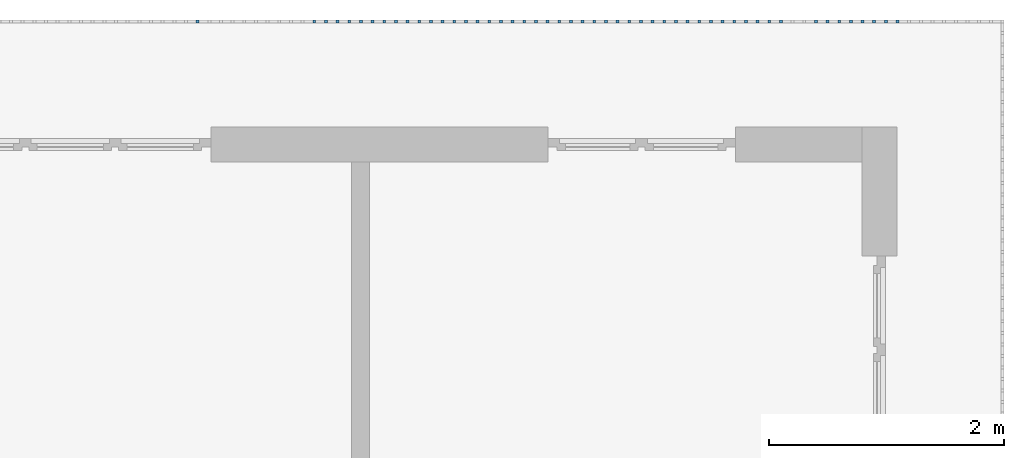
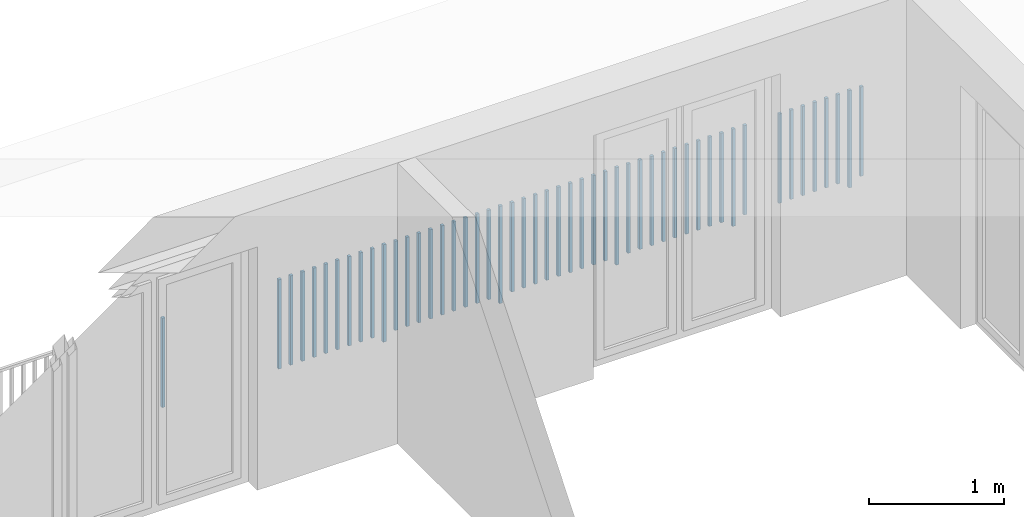
# One storey, part 53 of 54: 50 building element parts, 1 element without a shape of its own.
"""IFC4 building model written with IfcOpenShell, lengths in metres."""

from ifc_helpers import new_model, entity, si_unit, converted_unit, derived_unit, direction, frame, origin_with_axes, place, context, subcontext, project, spatial, polygons, material, type_object, element, aggregate, save


model = new_model("IFC4")

# Units and contexts
model_context = context("Model", 3, precision=1e-05, world=origin_with_axes(), true_north=direction((0.0, 1.0)))
body_context = subcontext(model_context, "Body", "Model", "MODEL_VIEW")
ifc_project = project(units=[si_unit("LENGTHUNIT", "METRE"), si_unit("AREAUNIT", "SQUARE_METRE"), si_unit("VOLUMEUNIT", "CUBIC_METRE"), converted_unit("PLANEANGLEUNIT", "DEGREE", entity("IfcPlaneAngleMeasure", 0.0174532925199), si_unit("PLANEANGLEUNIT", "RADIAN"), dimensions=[0, 0, 0, 0, 0, 0, 0]), converted_unit("TIMEUNIT", "Year", entity("IfcTimeMeasure", 31556926.0), si_unit("TIMEUNIT", "SECOND"), dimensions=[0, 0, 1, 0, 0, 0, 0]), si_unit("MASSUNIT", "GRAM", prefix="KILO"), si_unit("THERMODYNAMICTEMPERATUREUNIT", "DEGREE_CELSIUS"), si_unit("LUMINOUSINTENSITYUNIT", "LUMEN"), si_unit("ENERGYUNIT", "JOULE", prefix="MEGA"), derived_unit("THERMALCONDUCTANCEUNIT", [(si_unit("POWERUNIT", "WATT"), 1), (si_unit("LENGTHUNIT", "METRE"), -1), (si_unit("THERMODYNAMICTEMPERATUREUNIT", "KELVIN"), -1)]), derived_unit("SPECIFICHEATCAPACITYUNIT", [(si_unit("ENERGYUNIT", "JOULE"), 1), (si_unit("MASSUNIT", "GRAM", prefix="KILO"), -1), (si_unit("THERMODYNAMICTEMPERATUREUNIT", "KELVIN"), -1)]), derived_unit("MASSDENSITYUNIT", [(si_unit("MASSUNIT", "GRAM", prefix="KILO"), 1), (si_unit("VOLUMEUNIT", "CUBIC_METRE"), -1)])], contexts=[model_context])

# Site, building, storey, space
site_placement = place(None, origin_with_axes())
site = spatial("IfcSite", under=ifc_project, at=site_placement, CompositionType="ELEMENT")
building_placement = place(site_placement, origin_with_axes())
building = spatial("IfcBuilding", under=site, at=building_placement, CompositionType="ELEMENT")
storey_placement = place(building_placement, frame((0.0, 0.0, 9.18), z_axis=(0.0, 0.0, 1.0), x_axis=(1.0, 0.0, 0.0)))
storey = spatial("IfcBuildingStorey", under=building, at=storey_placement, Name="3. Geschoss", CompositionType="ELEMENT", Elevation=9.18)
space_placement = place(storey_placement, frame((10.2378006196, 9.82118769833, 0.0), z_axis=(0.0, 0.0, 1.0), x_axis=(-1.0, 0.0, 0.0)))
space = spatial("IfcSpace", under=storey, at=space_placement, CompositionType="ELEMENT", PredefinedType="EXTERNAL")

# Railing, building element parts
railing_type = type_object("IfcRailingType", PredefinedType="NOTDEFINED")
railing_placement = place(space_placement, frame((0.0, -7.06315681498e-08, 0.0), z_axis=(0.0, 0.0, 1.0), x_axis=(-1.0, 0.0, 0.0)))
railing = element("IfcRailing", 1, at=railing_placement, inside=space, type_object=railing_type, PredefinedType="NOTDEFINED")
ifc_material = material()
building_element_part_1_placement = place(railing_placement, origin_with_axes())
building_element_part_1 = element("IfcBuildingElementPart", 2, at=building_element_part_1_placement, material=ifc_material, PredefinedType="NOTDEFINED", context=body_context, shape_type="Tessellation", body=[
    polygons([(-0.907804347826, 0.0125, 0.07), (-0.907804347826, -0.0125, 0.07), (-0.907804347826, -0.0125, 0.8775), (-0.907804347826, 0.0125, 0.8775), (-0.882804347826, 0.0125, 0.07), (-0.882804347826, -0.0125, 0.07), (-0.882804347826, -0.0125, 0.8775), (-0.882804347826, 0.0125, 0.8775)], [[[1, 2, 3, 4]], [[1, 5, 6, 2]], [[2, 6, 7, 3]], [[4, 3, 7, 8]], [[5, 1, 4, 8]], [[6, 5, 8, 7]]], closed=True),
])
building_element_part_2_placement = place(railing_placement, origin_with_axes())
building_element_part_2 = element("IfcBuildingElementPart", 3, at=building_element_part_2_placement, material=ifc_material, PredefinedType="NOTDEFINED", context=body_context, shape_type="Tessellation", body=[
    polygons([(-1.0072826087, 0.0125, 0.0), (-1.0072826087, -0.0125, 0.0), (-1.0072826087, -0.0125, 0.88), (-1.0072826087, 0.0125, 0.88), (-0.982282608696, 0.0125, 0.0), (-0.982282608696, -0.0125, 0.0), (-0.982282608696, -0.0125, 0.88), (-0.982282608696, 0.0125, 0.88)], [[[1, 2, 3, 4]], [[1, 5, 6, 2]], [[2, 6, 7, 3]], [[4, 3, 7, 8]], [[5, 1, 4, 8]], [[6, 5, 8, 7]]], closed=True),
])
building_element_part_3_placement = place(railing_placement, origin_with_axes())
building_element_part_3 = element("IfcBuildingElementPart", 4, at=building_element_part_3_placement, material=ifc_material, PredefinedType="NOTDEFINED", context=body_context, shape_type="Tessellation", body=[
    polygons([(-1.10676086957, 0.0125, 0.07), (-1.10676086957, -0.0125, 0.07), (-1.10676086957, -0.0125, 0.8775), (-1.10676086957, 0.0125, 0.8775), (-1.08176086957, 0.0125, 0.07), (-1.08176086957, -0.0125, 0.07), (-1.08176086957, -0.0125, 0.8775), (-1.08176086957, 0.0125, 0.8775)], [[[1, 2, 3, 4]], [[1, 5, 6, 2]], [[2, 6, 7, 3]], [[4, 3, 7, 8]], [[5, 1, 4, 8]], [[6, 5, 8, 7]]], closed=True),
])
building_element_part_4_placement = place(railing_placement, origin_with_axes())
building_element_part_4 = element("IfcBuildingElementPart", 5, at=building_element_part_4_placement, material=ifc_material, PredefinedType="NOTDEFINED", context=body_context, shape_type="Tessellation", body=[
    polygons([(-1.20623913043, 0.0125, 0.07), (-1.20623913043, -0.0125, 0.07), (-1.20623913043, -0.0125, 0.8775), (-1.20623913043, 0.0125, 0.8775), (-1.18123913043, 0.0125, 0.07), (-1.18123913043, -0.0125, 0.07), (-1.18123913043, -0.0125, 0.8775), (-1.18123913043, 0.0125, 0.8775)], [[[1, 2, 3, 4]], [[1, 5, 6, 2]], [[2, 6, 7, 3]], [[4, 3, 7, 8]], [[5, 1, 4, 8]], [[6, 5, 8, 7]]], closed=True),
])
building_element_part_5_placement = place(railing_placement, origin_with_axes())
building_element_part_5 = element("IfcBuildingElementPart", 6, at=building_element_part_5_placement, material=ifc_material, PredefinedType="NOTDEFINED", context=body_context, shape_type="Tessellation", body=[
    polygons([(-1.3057173913, 0.0125, 0.07), (-1.3057173913, -0.0125, 0.07), (-1.3057173913, -0.0125, 0.8775), (-1.3057173913, 0.0125, 0.8775), (-1.2807173913, 0.0125, 0.07), (-1.2807173913, -0.0125, 0.07), (-1.2807173913, -0.0125, 0.8775), (-1.2807173913, 0.0125, 0.8775)], [[[1, 2, 3, 4]], [[1, 5, 6, 2]], [[2, 6, 7, 3]], [[4, 3, 7, 8]], [[5, 1, 4, 8]], [[6, 5, 8, 7]]], closed=True),
])
building_element_part_6_placement = place(railing_placement, origin_with_axes())
building_element_part_6 = element("IfcBuildingElementPart", 7, at=building_element_part_6_placement, material=ifc_material, PredefinedType="NOTDEFINED", context=body_context, shape_type="Tessellation", body=[
    polygons([(-1.40519565217, 0.0125, 0.07), (-1.40519565217, -0.0125, 0.07), (-1.40519565217, -0.0125, 0.8775), (-1.40519565217, 0.0125, 0.8775), (-1.38019565217, 0.0125, 0.07), (-1.38019565217, -0.0125, 0.07), (-1.38019565217, -0.0125, 0.8775), (-1.38019565217, 0.0125, 0.8775)], [[[1, 2, 3, 4]], [[1, 5, 6, 2]], [[2, 6, 7, 3]], [[4, 3, 7, 8]], [[5, 1, 4, 8]], [[6, 5, 8, 7]]], closed=True),
])
building_element_part_7_placement = place(railing_placement, origin_with_axes())
building_element_part_7 = element("IfcBuildingElementPart", 8, at=building_element_part_7_placement, material=ifc_material, PredefinedType="NOTDEFINED", context=body_context, shape_type="Tessellation", body=[
    polygons([(-1.50467391304, 0.0125, 0.07), (-1.50467391304, -0.0125, 0.07), (-1.50467391304, -0.0125, 0.8775), (-1.50467391304, 0.0125, 0.8775), (-1.47967391304, 0.0125, 0.07), (-1.47967391304, -0.0125, 0.07), (-1.47967391304, -0.0125, 0.8775), (-1.47967391304, 0.0125, 0.8775)], [[[1, 2, 3, 4]], [[1, 5, 6, 2]], [[2, 6, 7, 3]], [[4, 3, 7, 8]], [[5, 1, 4, 8]], [[6, 5, 8, 7]]], closed=True),
])
building_element_part_8_placement = place(railing_placement, origin_with_axes())
building_element_part_8 = element("IfcBuildingElementPart", 9, at=building_element_part_8_placement, material=ifc_material, PredefinedType="NOTDEFINED", context=body_context, shape_type="Tessellation", body=[
    polygons([(-1.60415217391, 0.0125, 0.07), (-1.60415217391, -0.0125, 0.07), (-1.60415217391, -0.0125, 0.8775), (-1.60415217391, 0.0125, 0.8775), (-1.57915217391, 0.0125, 0.07), (-1.57915217391, -0.0125, 0.07), (-1.57915217391, -0.0125, 0.8775), (-1.57915217391, 0.0125, 0.8775)], [[[1, 2, 3, 4]], [[1, 5, 6, 2]], [[2, 6, 7, 3]], [[4, 3, 7, 8]], [[5, 1, 4, 8]], [[6, 5, 8, 7]]], closed=True),
])
building_element_part_9_placement = place(railing_placement, origin_with_axes())
building_element_part_9 = element("IfcBuildingElementPart", 10, at=building_element_part_9_placement, material=ifc_material, PredefinedType="NOTDEFINED", context=body_context, shape_type="Tessellation", body=[
    polygons([(-1.90258695652, 0.0125, 0.07), (-1.90258695652, -0.0125, 0.07), (-1.90258695652, -0.0125, 0.8775), (-1.90258695652, 0.0125, 0.8775), (-1.87758695652, 0.0125, 0.07), (-1.87758695652, -0.0125, 0.07), (-1.87758695652, -0.0125, 0.8775), (-1.87758695652, 0.0125, 0.8775)], [[[1, 2, 3, 4]], [[1, 5, 6, 2]], [[2, 6, 7, 3]], [[4, 3, 7, 8]], [[5, 1, 4, 8]], [[6, 5, 8, 7]]], closed=True),
])
building_element_part_10_placement = place(railing_placement, origin_with_axes())
building_element_part_10 = element("IfcBuildingElementPart", 11, at=building_element_part_10_placement, material=ifc_material, PredefinedType="NOTDEFINED", context=body_context, shape_type="Tessellation", body=[
    polygons([(-2.00206521739, 0.0125, 0.0), (-2.00206521739, -0.0125, 0.0), (-2.00206521739, -0.0125, 0.88), (-2.00206521739, 0.0125, 0.88), (-1.97706521739, 0.0125, 0.0), (-1.97706521739, -0.0125, 0.0), (-1.97706521739, -0.0125, 0.88), (-1.97706521739, 0.0125, 0.88)], [[[1, 2, 3, 4]], [[1, 5, 6, 2]], [[2, 6, 7, 3]], [[4, 3, 7, 8]], [[5, 1, 4, 8]], [[6, 5, 8, 7]]], closed=True),
])
building_element_part_11_placement = place(railing_placement, origin_with_axes())
building_element_part_11 = element("IfcBuildingElementPart", 12, at=building_element_part_11_placement, material=ifc_material, PredefinedType="NOTDEFINED", context=body_context, shape_type="Tessellation", body=[
    polygons([(-2.10154347826, 0.0125, 0.07), (-2.10154347826, -0.0125, 0.07), (-2.10154347826, -0.0125, 0.8775), (-2.10154347826, 0.0125, 0.8775), (-2.07654347826, 0.0125, 0.07), (-2.07654347826, -0.0125, 0.07), (-2.07654347826, -0.0125, 0.8775), (-2.07654347826, 0.0125, 0.8775)], [[[1, 2, 3, 4]], [[1, 5, 6, 2]], [[2, 6, 7, 3]], [[4, 3, 7, 8]], [[5, 1, 4, 8]], [[6, 5, 8, 7]]], closed=True),
])
building_element_part_12_placement = place(railing_placement, origin_with_axes())
building_element_part_12 = element("IfcBuildingElementPart", 13, at=building_element_part_12_placement, material=ifc_material, PredefinedType="NOTDEFINED", context=body_context, shape_type="Tessellation", body=[
    polygons([(-2.20102173913, 0.0125, 0.07), (-2.20102173913, -0.0125, 0.07), (-2.20102173913, -0.0125, 0.8775), (-2.20102173913, 0.0125, 0.8775), (-2.17602173913, 0.0125, 0.07), (-2.17602173913, -0.0125, 0.07), (-2.17602173913, -0.0125, 0.8775), (-2.17602173913, 0.0125, 0.8775)], [[[1, 2, 3, 4]], [[1, 5, 6, 2]], [[2, 6, 7, 3]], [[4, 3, 7, 8]], [[5, 1, 4, 8]], [[6, 5, 8, 7]]], closed=True),
])
building_element_part_13_placement = place(railing_placement, origin_with_axes())
building_element_part_13 = element("IfcBuildingElementPart", 14, at=building_element_part_13_placement, material=ifc_material, PredefinedType="NOTDEFINED", context=body_context, shape_type="Tessellation", body=[
    polygons([(-2.3005, 0.0125, 0.07), (-2.3005, -0.0125, 0.07), (-2.3005, -0.0125, 0.8775), (-2.3005, 0.0125, 0.8775), (-2.2755, 0.0125, 0.07), (-2.2755, -0.0125, 0.07), (-2.2755, -0.0125, 0.8775), (-2.2755, 0.0125, 0.8775)], [[[1, 2, 3, 4]], [[1, 5, 6, 2]], [[2, 6, 7, 3]], [[4, 3, 7, 8]], [[5, 1, 4, 8]], [[6, 5, 8, 7]]], closed=True),
])
building_element_part_14_placement = place(railing_placement, origin_with_axes())
building_element_part_14 = element("IfcBuildingElementPart", 15, at=building_element_part_14_placement, material=ifc_material, PredefinedType="NOTDEFINED", context=body_context, shape_type="Tessellation", body=[
    polygons([(-2.39997826087, 0.0125, 0.07), (-2.39997826087, -0.0125, 0.07), (-2.39997826087, -0.0125, 0.8775), (-2.39997826087, 0.0125, 0.8775), (-2.37497826087, 0.0125, 0.07), (-2.37497826087, -0.0125, 0.07), (-2.37497826087, -0.0125, 0.8775), (-2.37497826087, 0.0125, 0.8775)], [[[1, 2, 3, 4]], [[1, 5, 6, 2]], [[2, 6, 7, 3]], [[4, 3, 7, 8]], [[5, 1, 4, 8]], [[6, 5, 8, 7]]], closed=True),
])
building_element_part_15_placement = place(railing_placement, origin_with_axes())
building_element_part_15 = element("IfcBuildingElementPart", 16, at=building_element_part_15_placement, material=ifc_material, PredefinedType="NOTDEFINED", context=body_context, shape_type="Tessellation", body=[
    polygons([(-2.49945652174, 0.0125, 0.07), (-2.49945652174, -0.0125, 0.07), (-2.49945652174, -0.0125, 0.8775), (-2.49945652174, 0.0125, 0.8775), (-2.47445652174, 0.0125, 0.07), (-2.47445652174, -0.0125, 0.07), (-2.47445652174, -0.0125, 0.8775), (-2.47445652174, 0.0125, 0.8775)], [[[1, 2, 3, 4]], [[1, 5, 6, 2]], [[2, 6, 7, 3]], [[4, 3, 7, 8]], [[5, 1, 4, 8]], [[6, 5, 8, 7]]], closed=True),
])
building_element_part_16_placement = place(railing_placement, origin_with_axes())
building_element_part_16 = element("IfcBuildingElementPart", 17, at=building_element_part_16_placement, material=ifc_material, PredefinedType="NOTDEFINED", context=body_context, shape_type="Tessellation", body=[
    polygons([(-2.59893478261, 0.0125, 0.07), (-2.59893478261, -0.0125, 0.07), (-2.59893478261, -0.0125, 0.8775), (-2.59893478261, 0.0125, 0.8775), (-2.57393478261, 0.0125, 0.07), (-2.57393478261, -0.0125, 0.07), (-2.57393478261, -0.0125, 0.8775), (-2.57393478261, 0.0125, 0.8775)], [[[1, 2, 3, 4]], [[1, 5, 6, 2]], [[2, 6, 7, 3]], [[4, 3, 7, 8]], [[5, 1, 4, 8]], [[6, 5, 8, 7]]], closed=True),
])
building_element_part_17_placement = place(railing_placement, origin_with_axes())
building_element_part_17 = element("IfcBuildingElementPart", 18, at=building_element_part_17_placement, material=ifc_material, PredefinedType="NOTDEFINED", context=body_context, shape_type="Tessellation", body=[
    polygons([(-2.69841304348, 0.0125, 0.07), (-2.69841304348, -0.0125, 0.07), (-2.69841304348, -0.0125, 0.8775), (-2.69841304348, 0.0125, 0.8775), (-2.67341304348, 0.0125, 0.07), (-2.67341304348, -0.0125, 0.07), (-2.67341304348, -0.0125, 0.8775), (-2.67341304348, 0.0125, 0.8775)], [[[1, 2, 3, 4]], [[1, 5, 6, 2]], [[2, 6, 7, 3]], [[4, 3, 7, 8]], [[5, 1, 4, 8]], [[6, 5, 8, 7]]], closed=True),
])
building_element_part_18_placement = place(railing_placement, origin_with_axes())
building_element_part_18 = element("IfcBuildingElementPart", 19, at=building_element_part_18_placement, material=ifc_material, PredefinedType="NOTDEFINED", context=body_context, shape_type="Tessellation", body=[
    polygons([(-2.79789130435, 0.0125, 0.07), (-2.79789130435, -0.0125, 0.07), (-2.79789130435, -0.0125, 0.8775), (-2.79789130435, 0.0125, 0.8775), (-2.77289130435, 0.0125, 0.07), (-2.77289130435, -0.0125, 0.07), (-2.77289130435, -0.0125, 0.8775), (-2.77289130435, 0.0125, 0.8775)], [[[1, 2, 3, 4]], [[1, 5, 6, 2]], [[2, 6, 7, 3]], [[4, 3, 7, 8]], [[5, 1, 4, 8]], [[6, 5, 8, 7]]], closed=True),
])
building_element_part_19_placement = place(railing_placement, origin_with_axes())
building_element_part_19 = element("IfcBuildingElementPart", 20, at=building_element_part_19_placement, material=ifc_material, PredefinedType="NOTDEFINED", context=body_context, shape_type="Tessellation", body=[
    polygons([(-2.89736956522, 0.0125, 0.07), (-2.89736956522, -0.0125, 0.07), (-2.89736956522, -0.0125, 0.8775), (-2.89736956522, 0.0125, 0.8775), (-2.87236956522, 0.0125, 0.07), (-2.87236956522, -0.0125, 0.07), (-2.87236956522, -0.0125, 0.8775), (-2.87236956522, 0.0125, 0.8775)], [[[1, 2, 3, 4]], [[1, 5, 6, 2]], [[2, 6, 7, 3]], [[4, 3, 7, 8]], [[5, 1, 4, 8]], [[6, 5, 8, 7]]], closed=True),
])
building_element_part_20_placement = place(railing_placement, origin_with_axes())
building_element_part_20 = element("IfcBuildingElementPart", 21, at=building_element_part_20_placement, material=ifc_material, PredefinedType="NOTDEFINED", context=body_context, shape_type="Tessellation", body=[
    polygons([(-2.99684782609, 0.0125, 0.0), (-2.99684782609, -0.0125, 0.0), (-2.99684782609, -0.0125, 0.88), (-2.99684782609, 0.0125, 0.88), (-2.97184782609, 0.0125, 0.0), (-2.97184782609, -0.0125, 0.0), (-2.97184782609, -0.0125, 0.88), (-2.97184782609, 0.0125, 0.88)], [[[1, 2, 3, 4]], [[1, 5, 6, 2]], [[2, 6, 7, 3]], [[4, 3, 7, 8]], [[5, 1, 4, 8]], [[6, 5, 8, 7]]], closed=True),
])
building_element_part_21_placement = place(railing_placement, origin_with_axes())
building_element_part_21 = element("IfcBuildingElementPart", 22, at=building_element_part_21_placement, material=ifc_material, PredefinedType="NOTDEFINED", context=body_context, shape_type="Tessellation", body=[
    polygons([(-3.09632608696, 0.0125, 0.07), (-3.09632608696, -0.0125, 0.07), (-3.09632608696, -0.0125, 0.8775), (-3.09632608696, 0.0125, 0.8775), (-3.07132608696, 0.0125, 0.07), (-3.07132608696, -0.0125, 0.07), (-3.07132608696, -0.0125, 0.8775), (-3.07132608696, 0.0125, 0.8775)], [[[1, 2, 3, 4]], [[1, 5, 6, 2]], [[2, 6, 7, 3]], [[4, 3, 7, 8]], [[5, 1, 4, 8]], [[6, 5, 8, 7]]], closed=True),
])
building_element_part_22_placement = place(railing_placement, origin_with_axes())
building_element_part_22 = element("IfcBuildingElementPart", 23, at=building_element_part_22_placement, material=ifc_material, PredefinedType="NOTDEFINED", context=body_context, shape_type="Tessellation", body=[
    polygons([(-3.19580434783, 0.0125, 0.07), (-3.19580434783, -0.0125, 0.07), (-3.19580434783, -0.0125, 0.8775), (-3.19580434783, 0.0125, 0.8775), (-3.17080434783, 0.0125, 0.07), (-3.17080434783, -0.0125, 0.07), (-3.17080434783, -0.0125, 0.8775), (-3.17080434783, 0.0125, 0.8775)], [[[1, 2, 3, 4]], [[1, 5, 6, 2]], [[2, 6, 7, 3]], [[4, 3, 7, 8]], [[5, 1, 4, 8]], [[6, 5, 8, 7]]], closed=True),
])
building_element_part_23_placement = place(railing_placement, origin_with_axes())
building_element_part_23 = element("IfcBuildingElementPart", 24, at=building_element_part_23_placement, material=ifc_material, PredefinedType="NOTDEFINED", context=body_context, shape_type="Tessellation", body=[
    polygons([(-3.2952826087, 0.0125, 0.07), (-3.2952826087, -0.0125, 0.07), (-3.2952826087, -0.0125, 0.8775), (-3.2952826087, 0.0125, 0.8775), (-3.2702826087, 0.0125, 0.07), (-3.2702826087, -0.0125, 0.07), (-3.2702826087, -0.0125, 0.8775), (-3.2702826087, 0.0125, 0.8775)], [[[1, 2, 3, 4]], [[1, 5, 6, 2]], [[2, 6, 7, 3]], [[4, 3, 7, 8]], [[5, 1, 4, 8]], [[6, 5, 8, 7]]], closed=True),
])
building_element_part_24_placement = place(railing_placement, origin_with_axes())
building_element_part_24 = element("IfcBuildingElementPart", 25, at=building_element_part_24_placement, material=ifc_material, PredefinedType="NOTDEFINED", context=body_context, shape_type="Tessellation", body=[
    polygons([(-3.39476086957, 0.0125, 0.07), (-3.39476086957, -0.0125, 0.07), (-3.39476086957, -0.0125, 0.8775), (-3.39476086957, 0.0125, 0.8775), (-3.36976086957, 0.0125, 0.07), (-3.36976086957, -0.0125, 0.07), (-3.36976086957, -0.0125, 0.8775), (-3.36976086957, 0.0125, 0.8775)], [[[1, 2, 3, 4]], [[1, 5, 6, 2]], [[2, 6, 7, 3]], [[4, 3, 7, 8]], [[5, 1, 4, 8]], [[6, 5, 8, 7]]], closed=True),
])
building_element_part_25_placement = place(railing_placement, origin_with_axes())
building_element_part_25 = element("IfcBuildingElementPart", 26, at=building_element_part_25_placement, material=ifc_material, PredefinedType="NOTDEFINED", context=body_context, shape_type="Tessellation", body=[
    polygons([(-3.49423913043, 0.0125, 0.07), (-3.49423913043, -0.0125, 0.07), (-3.49423913043, -0.0125, 0.8775), (-3.49423913043, 0.0125, 0.8775), (-3.46923913043, 0.0125, 0.07), (-3.46923913043, -0.0125, 0.07), (-3.46923913043, -0.0125, 0.8775), (-3.46923913043, 0.0125, 0.8775)], [[[1, 2, 3, 4]], [[1, 5, 6, 2]], [[2, 6, 7, 3]], [[4, 3, 7, 8]], [[5, 1, 4, 8]], [[6, 5, 8, 7]]], closed=True),
])
building_element_part_26_placement = place(railing_placement, origin_with_axes())
building_element_part_26 = element("IfcBuildingElementPart", 27, at=building_element_part_26_placement, material=ifc_material, PredefinedType="NOTDEFINED", context=body_context, shape_type="Tessellation", body=[
    polygons([(-3.5937173913, 0.0125, 0.07), (-3.5937173913, -0.0125, 0.07), (-3.5937173913, -0.0125, 0.8775), (-3.5937173913, 0.0125, 0.8775), (-3.5687173913, 0.0125, 0.07), (-3.5687173913, -0.0125, 0.07), (-3.5687173913, -0.0125, 0.8775), (-3.5687173913, 0.0125, 0.8775)], [[[1, 2, 3, 4]], [[1, 5, 6, 2]], [[2, 6, 7, 3]], [[4, 3, 7, 8]], [[5, 1, 4, 8]], [[6, 5, 8, 7]]], closed=True),
])
building_element_part_27_placement = place(railing_placement, origin_with_axes())
building_element_part_27 = element("IfcBuildingElementPart", 28, at=building_element_part_27_placement, material=ifc_material, PredefinedType="NOTDEFINED", context=body_context, shape_type="Tessellation", body=[
    polygons([(-3.69319565217, 0.0125, 0.07), (-3.69319565217, -0.0125, 0.07), (-3.69319565217, -0.0125, 0.8775), (-3.69319565217, 0.0125, 0.8775), (-3.66819565217, 0.0125, 0.07), (-3.66819565217, -0.0125, 0.07), (-3.66819565217, -0.0125, 0.8775), (-3.66819565217, 0.0125, 0.8775)], [[[1, 2, 3, 4]], [[1, 5, 6, 2]], [[2, 6, 7, 3]], [[4, 3, 7, 8]], [[5, 1, 4, 8]], [[6, 5, 8, 7]]], closed=True),
])
building_element_part_28_placement = place(railing_placement, origin_with_axes())
building_element_part_28 = element("IfcBuildingElementPart", 29, at=building_element_part_28_placement, material=ifc_material, PredefinedType="NOTDEFINED", context=body_context, shape_type="Tessellation", body=[
    polygons([(-3.79267391304, 0.0125, 0.07), (-3.79267391304, -0.0125, 0.07), (-3.79267391304, -0.0125, 0.8775), (-3.79267391304, 0.0125, 0.8775), (-3.76767391304, 0.0125, 0.07), (-3.76767391304, -0.0125, 0.07), (-3.76767391304, -0.0125, 0.8775), (-3.76767391304, 0.0125, 0.8775)], [[[1, 2, 3, 4]], [[1, 5, 6, 2]], [[2, 6, 7, 3]], [[4, 3, 7, 8]], [[5, 1, 4, 8]], [[6, 5, 8, 7]]], closed=True),
])
building_element_part_29_placement = place(railing_placement, origin_with_axes())
building_element_part_29 = element("IfcBuildingElementPart", 30, at=building_element_part_29_placement, material=ifc_material, PredefinedType="NOTDEFINED", context=body_context, shape_type="Tessellation", body=[
    polygons([(-3.89215217391, 0.0125, 0.07), (-3.89215217391, -0.0125, 0.07), (-3.89215217391, -0.0125, 0.8775), (-3.89215217391, 0.0125, 0.8775), (-3.86715217391, 0.0125, 0.07), (-3.86715217391, -0.0125, 0.07), (-3.86715217391, -0.0125, 0.8775), (-3.86715217391, 0.0125, 0.8775)], [[[1, 2, 3, 4]], [[1, 5, 6, 2]], [[2, 6, 7, 3]], [[4, 3, 7, 8]], [[5, 1, 4, 8]], [[6, 5, 8, 7]]], closed=True),
])
building_element_part_30_placement = place(railing_placement, origin_with_axes())
building_element_part_30 = element("IfcBuildingElementPart", 31, at=building_element_part_30_placement, material=ifc_material, PredefinedType="NOTDEFINED", context=body_context, shape_type="Tessellation", body=[
    polygons([(-3.99163043478, 0.0125, 0.0), (-3.99163043478, -0.0125, 0.0), (-3.99163043478, -0.0125, 0.88), (-3.99163043478, 0.0125, 0.88), (-3.96663043478, 0.0125, 0.0), (-3.96663043478, -0.0125, 0.0), (-3.96663043478, -0.0125, 0.88), (-3.96663043478, 0.0125, 0.88)], [[[1, 2, 3, 4]], [[1, 5, 6, 2]], [[2, 6, 7, 3]], [[4, 3, 7, 8]], [[5, 1, 4, 8]], [[6, 5, 8, 7]]], closed=True),
])
building_element_part_31_placement = place(railing_placement, origin_with_axes())
building_element_part_31 = element("IfcBuildingElementPart", 32, at=building_element_part_31_placement, material=ifc_material, PredefinedType="NOTDEFINED", context=body_context, shape_type="Tessellation", body=[
    polygons([(-4.09110869565, 0.0125, 0.07), (-4.09110869565, -0.0125, 0.07), (-4.09110869565, -0.0125, 0.8775), (-4.09110869565, 0.0125, 0.8775), (-4.06610869565, 0.0125, 0.07), (-4.06610869565, -0.0125, 0.07), (-4.06610869565, -0.0125, 0.8775), (-4.06610869565, 0.0125, 0.8775)], [[[1, 2, 3, 4]], [[1, 5, 6, 2]], [[2, 6, 7, 3]], [[4, 3, 7, 8]], [[5, 1, 4, 8]], [[6, 5, 8, 7]]], closed=True),
])
building_element_part_32_placement = place(railing_placement, origin_with_axes())
building_element_part_32 = element("IfcBuildingElementPart", 33, at=building_element_part_32_placement, material=ifc_material, PredefinedType="NOTDEFINED", context=body_context, shape_type="Tessellation", body=[
    polygons([(-4.19058695652, 0.0125, 0.07), (-4.19058695652, -0.0125, 0.07), (-4.19058695652, -0.0125, 0.8775), (-4.19058695652, 0.0125, 0.8775), (-4.16558695652, 0.0125, 0.07), (-4.16558695652, -0.0125, 0.07), (-4.16558695652, -0.0125, 0.8775), (-4.16558695652, 0.0125, 0.8775)], [[[1, 2, 3, 4]], [[1, 5, 6, 2]], [[2, 6, 7, 3]], [[4, 3, 7, 8]], [[5, 1, 4, 8]], [[6, 5, 8, 7]]], closed=True),
])
building_element_part_33_placement = place(railing_placement, origin_with_axes())
building_element_part_33 = element("IfcBuildingElementPart", 34, at=building_element_part_33_placement, material=ifc_material, PredefinedType="NOTDEFINED", context=body_context, shape_type="Tessellation", body=[
    polygons([(-4.29006521739, 0.0125, 0.07), (-4.29006521739, -0.0125, 0.07), (-4.29006521739, -0.0125, 0.8775), (-4.29006521739, 0.0125, 0.8775), (-4.26506521739, 0.0125, 0.07), (-4.26506521739, -0.0125, 0.07), (-4.26506521739, -0.0125, 0.8775), (-4.26506521739, 0.0125, 0.8775)], [[[1, 2, 3, 4]], [[1, 5, 6, 2]], [[2, 6, 7, 3]], [[4, 3, 7, 8]], [[5, 1, 4, 8]], [[6, 5, 8, 7]]], closed=True),
])
building_element_part_34_placement = place(railing_placement, origin_with_axes())
building_element_part_34 = element("IfcBuildingElementPart", 35, at=building_element_part_34_placement, material=ifc_material, PredefinedType="NOTDEFINED", context=body_context, shape_type="Tessellation", body=[
    polygons([(-4.38954347826, 0.0125, 0.07), (-4.38954347826, -0.0125, 0.07), (-4.38954347826, -0.0125, 0.8775), (-4.38954347826, 0.0125, 0.8775), (-4.36454347826, 0.0125, 0.07), (-4.36454347826, -0.0125, 0.07), (-4.36454347826, -0.0125, 0.8775), (-4.36454347826, 0.0125, 0.8775)], [[[1, 2, 3, 4]], [[1, 5, 6, 2]], [[2, 6, 7, 3]], [[4, 3, 7, 8]], [[5, 1, 4, 8]], [[6, 5, 8, 7]]], closed=True),
])
building_element_part_35_placement = place(railing_placement, origin_with_axes())
building_element_part_35 = element("IfcBuildingElementPart", 36, at=building_element_part_35_placement, material=ifc_material, PredefinedType="NOTDEFINED", context=body_context, shape_type="Tessellation", body=[
    polygons([(-4.48902173913, 0.0125, 0.07), (-4.48902173913, -0.0125, 0.07), (-4.48902173913, -0.0125, 0.8775), (-4.48902173913, 0.0125, 0.8775), (-4.46402173913, 0.0125, 0.07), (-4.46402173913, -0.0125, 0.07), (-4.46402173913, -0.0125, 0.8775), (-4.46402173913, 0.0125, 0.8775)], [[[1, 2, 3, 4]], [[1, 5, 6, 2]], [[2, 6, 7, 3]], [[4, 3, 7, 8]], [[5, 1, 4, 8]], [[6, 5, 8, 7]]], closed=True),
])
building_element_part_36_placement = place(railing_placement, origin_with_axes())
building_element_part_36 = element("IfcBuildingElementPart", 37, at=building_element_part_36_placement, material=ifc_material, PredefinedType="NOTDEFINED", context=body_context, shape_type="Tessellation", body=[
    polygons([(-4.5885, 0.0125, 0.07), (-4.5885, -0.0125, 0.07), (-4.5885, -0.0125, 0.8775), (-4.5885, 0.0125, 0.8775), (-4.5635, 0.0125, 0.07), (-4.5635, -0.0125, 0.07), (-4.5635, -0.0125, 0.8775), (-4.5635, 0.0125, 0.8775)], [[[1, 2, 3, 4]], [[1, 5, 6, 2]], [[2, 6, 7, 3]], [[4, 3, 7, 8]], [[5, 1, 4, 8]], [[6, 5, 8, 7]]], closed=True),
])
building_element_part_37_placement = place(railing_placement, origin_with_axes())
building_element_part_37 = element("IfcBuildingElementPart", 38, at=building_element_part_37_placement, material=ifc_material, PredefinedType="NOTDEFINED", context=body_context, shape_type="Tessellation", body=[
    polygons([(-4.68797826087, 0.0125, 0.07), (-4.68797826087, -0.0125, 0.07), (-4.68797826087, -0.0125, 0.8775), (-4.68797826087, 0.0125, 0.8775), (-4.66297826087, 0.0125, 0.07), (-4.66297826087, -0.0125, 0.07), (-4.66297826087, -0.0125, 0.8775), (-4.66297826087, 0.0125, 0.8775)], [[[1, 2, 3, 4]], [[1, 5, 6, 2]], [[2, 6, 7, 3]], [[4, 3, 7, 8]], [[5, 1, 4, 8]], [[6, 5, 8, 7]]], closed=True),
])
building_element_part_38_placement = place(railing_placement, origin_with_axes())
building_element_part_38 = element("IfcBuildingElementPart", 39, at=building_element_part_38_placement, material=ifc_material, PredefinedType="NOTDEFINED", context=body_context, shape_type="Tessellation", body=[
    polygons([(-4.78745652174, 0.0125, 0.07), (-4.78745652174, -0.0125, 0.07), (-4.78745652174, -0.0125, 0.8775), (-4.78745652174, 0.0125, 0.8775), (-4.76245652174, 0.0125, 0.07), (-4.76245652174, -0.0125, 0.07), (-4.76245652174, -0.0125, 0.8775), (-4.76245652174, 0.0125, 0.8775)], [[[1, 2, 3, 4]], [[1, 5, 6, 2]], [[2, 6, 7, 3]], [[4, 3, 7, 8]], [[5, 1, 4, 8]], [[6, 5, 8, 7]]], closed=True),
])
building_element_part_39_placement = place(railing_placement, origin_with_axes())
building_element_part_39 = element("IfcBuildingElementPart", 40, at=building_element_part_39_placement, material=ifc_material, PredefinedType="NOTDEFINED", context=body_context, shape_type="Tessellation", body=[
    polygons([(-4.88693478261, 0.0125, 0.07), (-4.88693478261, -0.0125, 0.07), (-4.88693478261, -0.0125, 0.8775), (-4.88693478261, 0.0125, 0.8775), (-4.86193478261, 0.0125, 0.07), (-4.86193478261, -0.0125, 0.07), (-4.86193478261, -0.0125, 0.8775), (-4.86193478261, 0.0125, 0.8775)], [[[1, 2, 3, 4]], [[1, 5, 6, 2]], [[2, 6, 7, 3]], [[4, 3, 7, 8]], [[5, 1, 4, 8]], [[6, 5, 8, 7]]], closed=True),
])
building_element_part_40_placement = place(railing_placement, origin_with_axes())
building_element_part_40 = element("IfcBuildingElementPart", 41, at=building_element_part_40_placement, material=ifc_material, PredefinedType="NOTDEFINED", context=body_context, shape_type="Tessellation", body=[
    polygons([(-4.98641304348, 0.0125, 0.0), (-4.98641304348, -0.0125, 0.0), (-4.98641304348, -0.0125, 0.88), (-4.98641304348, 0.0125, 0.88), (-4.96141304348, 0.0125, 0.0), (-4.96141304348, -0.0125, 0.0), (-4.96141304348, -0.0125, 0.88), (-4.96141304348, 0.0125, 0.88)], [[[1, 2, 3, 4]], [[1, 5, 6, 2]], [[2, 6, 7, 3]], [[4, 3, 7, 8]], [[5, 1, 4, 8]], [[6, 5, 8, 7]]], closed=True),
])
building_element_part_41_placement = place(railing_placement, origin_with_axes())
building_element_part_41 = element("IfcBuildingElementPart", 42, at=building_element_part_41_placement, material=ifc_material, PredefinedType="NOTDEFINED", context=body_context, shape_type="Tessellation", body=[
    polygons([(-5.08589130435, 0.0125, 0.07), (-5.08589130435, -0.0125, 0.07), (-5.08589130435, -0.0125, 0.8775), (-5.08589130435, 0.0125, 0.8775), (-5.06089130435, 0.0125, 0.07), (-5.06089130435, -0.0125, 0.07), (-5.06089130435, -0.0125, 0.8775), (-5.06089130435, 0.0125, 0.8775)], [[[1, 2, 3, 4]], [[1, 5, 6, 2]], [[2, 6, 7, 3]], [[4, 3, 7, 8]], [[5, 1, 4, 8]], [[6, 5, 8, 7]]], closed=True),
])
building_element_part_42_placement = place(railing_placement, origin_with_axes())
building_element_part_42 = element("IfcBuildingElementPart", 43, at=building_element_part_42_placement, material=ifc_material, PredefinedType="NOTDEFINED", context=body_context, shape_type="Tessellation", body=[
    polygons([(-5.18536956522, 0.0125, 0.07), (-5.18536956522, -0.0125, 0.07), (-5.18536956522, -0.0125, 0.8775), (-5.18536956522, 0.0125, 0.8775), (-5.16036956522, 0.0125, 0.07), (-5.16036956522, -0.0125, 0.07), (-5.16036956522, -0.0125, 0.8775), (-5.16036956522, 0.0125, 0.8775)], [[[1, 2, 3, 4]], [[1, 5, 6, 2]], [[2, 6, 7, 3]], [[4, 3, 7, 8]], [[5, 1, 4, 8]], [[6, 5, 8, 7]]], closed=True),
])
building_element_part_43_placement = place(railing_placement, origin_with_axes())
building_element_part_43 = element("IfcBuildingElementPart", 44, at=building_element_part_43_placement, material=ifc_material, PredefinedType="NOTDEFINED", context=body_context, shape_type="Tessellation", body=[
    polygons([(-5.28484782609, 0.0125, 0.07), (-5.28484782609, -0.0125, 0.07), (-5.28484782609, -0.0125, 0.8775), (-5.28484782609, 0.0125, 0.8775), (-5.25984782609, 0.0125, 0.07), (-5.25984782609, -0.0125, 0.07), (-5.25984782609, -0.0125, 0.8775), (-5.25984782609, 0.0125, 0.8775)], [[[1, 2, 3, 4]], [[1, 5, 6, 2]], [[2, 6, 7, 3]], [[4, 3, 7, 8]], [[5, 1, 4, 8]], [[6, 5, 8, 7]]], closed=True),
])
building_element_part_44_placement = place(railing_placement, origin_with_axes())
building_element_part_44 = element("IfcBuildingElementPart", 45, at=building_element_part_44_placement, material=ifc_material, PredefinedType="NOTDEFINED", context=body_context, shape_type="Tessellation", body=[
    polygons([(-5.38432608696, 0.0125, 0.07), (-5.38432608696, -0.0125, 0.07), (-5.38432608696, -0.0125, 0.8775), (-5.38432608696, 0.0125, 0.8775), (-5.35932608696, 0.0125, 0.07), (-5.35932608696, -0.0125, 0.07), (-5.35932608696, -0.0125, 0.8775), (-5.35932608696, 0.0125, 0.8775)], [[[1, 2, 3, 4]], [[1, 5, 6, 2]], [[2, 6, 7, 3]], [[4, 3, 7, 8]], [[5, 1, 4, 8]], [[6, 5, 8, 7]]], closed=True),
])
building_element_part_45_placement = place(railing_placement, origin_with_axes())
building_element_part_45 = element("IfcBuildingElementPart", 46, at=building_element_part_45_placement, material=ifc_material, PredefinedType="NOTDEFINED", context=body_context, shape_type="Tessellation", body=[
    polygons([(-5.48380434783, 0.0125, 0.07), (-5.48380434783, -0.0125, 0.07), (-5.48380434783, -0.0125, 0.8775), (-5.48380434783, 0.0125, 0.8775), (-5.45880434783, 0.0125, 0.07), (-5.45880434783, -0.0125, 0.07), (-5.45880434783, -0.0125, 0.8775), (-5.45880434783, 0.0125, 0.8775)], [[[1, 2, 3, 4]], [[1, 5, 6, 2]], [[2, 6, 7, 3]], [[4, 3, 7, 8]], [[5, 1, 4, 8]], [[6, 5, 8, 7]]], closed=True),
])
building_element_part_46_placement = place(railing_placement, origin_with_axes())
building_element_part_46 = element("IfcBuildingElementPart", 47, at=building_element_part_46_placement, material=ifc_material, PredefinedType="NOTDEFINED", context=body_context, shape_type="Tessellation", body=[
    polygons([(-5.5832826087, 0.0125, 0.07), (-5.5832826087, -0.0125, 0.07), (-5.5832826087, -0.0125, 0.8775), (-5.5832826087, 0.0125, 0.8775), (-5.5582826087, 0.0125, 0.07), (-5.5582826087, -0.0125, 0.07), (-5.5582826087, -0.0125, 0.8775), (-5.5582826087, 0.0125, 0.8775)], [[[1, 2, 3, 4]], [[1, 5, 6, 2]], [[2, 6, 7, 3]], [[4, 3, 7, 8]], [[5, 1, 4, 8]], [[6, 5, 8, 7]]], closed=True),
])
building_element_part_47_placement = place(railing_placement, origin_with_axes())
building_element_part_47 = element("IfcBuildingElementPart", 48, at=building_element_part_47_placement, material=ifc_material, PredefinedType="NOTDEFINED", context=body_context, shape_type="Tessellation", body=[
    polygons([(-5.68276086957, 0.0125, 0.07), (-5.68276086957, -0.0125, 0.07), (-5.68276086957, -0.0125, 0.8775), (-5.68276086957, 0.0125, 0.8775), (-5.65776086957, 0.0125, 0.07), (-5.65776086957, -0.0125, 0.07), (-5.65776086957, -0.0125, 0.8775), (-5.65776086957, 0.0125, 0.8775)], [[[1, 2, 3, 4]], [[1, 5, 6, 2]], [[2, 6, 7, 3]], [[4, 3, 7, 8]], [[5, 1, 4, 8]], [[6, 5, 8, 7]]], closed=True),
])
building_element_part_48_placement = place(railing_placement, origin_with_axes())
building_element_part_48 = element("IfcBuildingElementPart", 49, at=building_element_part_48_placement, material=ifc_material, PredefinedType="NOTDEFINED", context=body_context, shape_type="Tessellation", body=[
    polygons([(-5.78223913043, 0.0125, 0.07), (-5.78223913043, -0.0125, 0.07), (-5.78223913043, -0.0125, 0.8775), (-5.78223913043, 0.0125, 0.8775), (-5.75723913043, 0.0125, 0.07), (-5.75723913043, -0.0125, 0.07), (-5.75723913043, -0.0125, 0.8775), (-5.75723913043, 0.0125, 0.8775)], [[[1, 2, 3, 4]], [[1, 5, 6, 2]], [[2, 6, 7, 3]], [[4, 3, 7, 8]], [[5, 1, 4, 8]], [[6, 5, 8, 7]]], closed=True),
])
building_element_part_49_placement = place(railing_placement, origin_with_axes())
building_element_part_49 = element("IfcBuildingElementPart", 50, at=building_element_part_49_placement, material=ifc_material, PredefinedType="NOTDEFINED", context=body_context, shape_type="Tessellation", body=[
    polygons([(-5.8817173913, 0.0125, 0.07), (-5.8817173913, -0.0125, 0.07), (-5.8817173913, -0.0125, 0.8775), (-5.8817173913, 0.0125, 0.8775), (-5.8567173913, 0.0125, 0.07), (-5.8567173913, -0.0125, 0.07), (-5.8567173913, -0.0125, 0.8775), (-5.8567173913, 0.0125, 0.8775)], [[[1, 2, 3, 4]], [[1, 5, 6, 2]], [[2, 6, 7, 3]], [[4, 3, 7, 8]], [[5, 1, 4, 8]], [[6, 5, 8, 7]]], closed=True),
])
building_element_part_50_placement = place(railing_placement, origin_with_axes())
building_element_part_50 = element("IfcBuildingElementPart", 51, at=building_element_part_50_placement, material=ifc_material, PredefinedType="NOTDEFINED", context=body_context, shape_type="Tessellation", body=[
    polygons([(-6.8765, 0.0125, 0.07), (-6.8765, -0.0125, 0.07), (-6.8765, -0.0125, 0.8775), (-6.8765, 0.0125, 0.8775), (-6.8515, 0.0125, 0.07), (-6.8515, -0.0125, 0.07), (-6.8515, -0.0125, 0.8775), (-6.8515, 0.0125, 0.8775)], [[[1, 2, 3, 4]], [[1, 5, 6, 2]], [[2, 6, 7, 3]], [[4, 3, 7, 8]], [[5, 1, 4, 8]], [[6, 5, 8, 7]]], closed=True),
])
aggregate(railing, [building_element_part_1, building_element_part_2, building_element_part_3, building_element_part_4, building_element_part_5, building_element_part_6, building_element_part_7, building_element_part_8, building_element_part_9, building_element_part_10, building_element_part_11, building_element_part_12, building_element_part_13, building_element_part_14, building_element_part_15, building_element_part_16, building_element_part_17, building_element_part_18, building_element_part_19, building_element_part_20, building_element_part_21, building_element_part_22, building_element_part_23, building_element_part_24, building_element_part_25, building_element_part_26, building_element_part_27, building_element_part_28, building_element_part_29, building_element_part_30, building_element_part_31, building_element_part_32, building_element_part_33, building_element_part_34, building_element_part_35, building_element_part_36, building_element_part_37, building_element_part_38, building_element_part_39, building_element_part_40, building_element_part_41, building_element_part_42, building_element_part_43, building_element_part_44, building_element_part_45, building_element_part_46, building_element_part_47, building_element_part_48, building_element_part_49, building_element_part_50])

save(model, "model.ifc")
